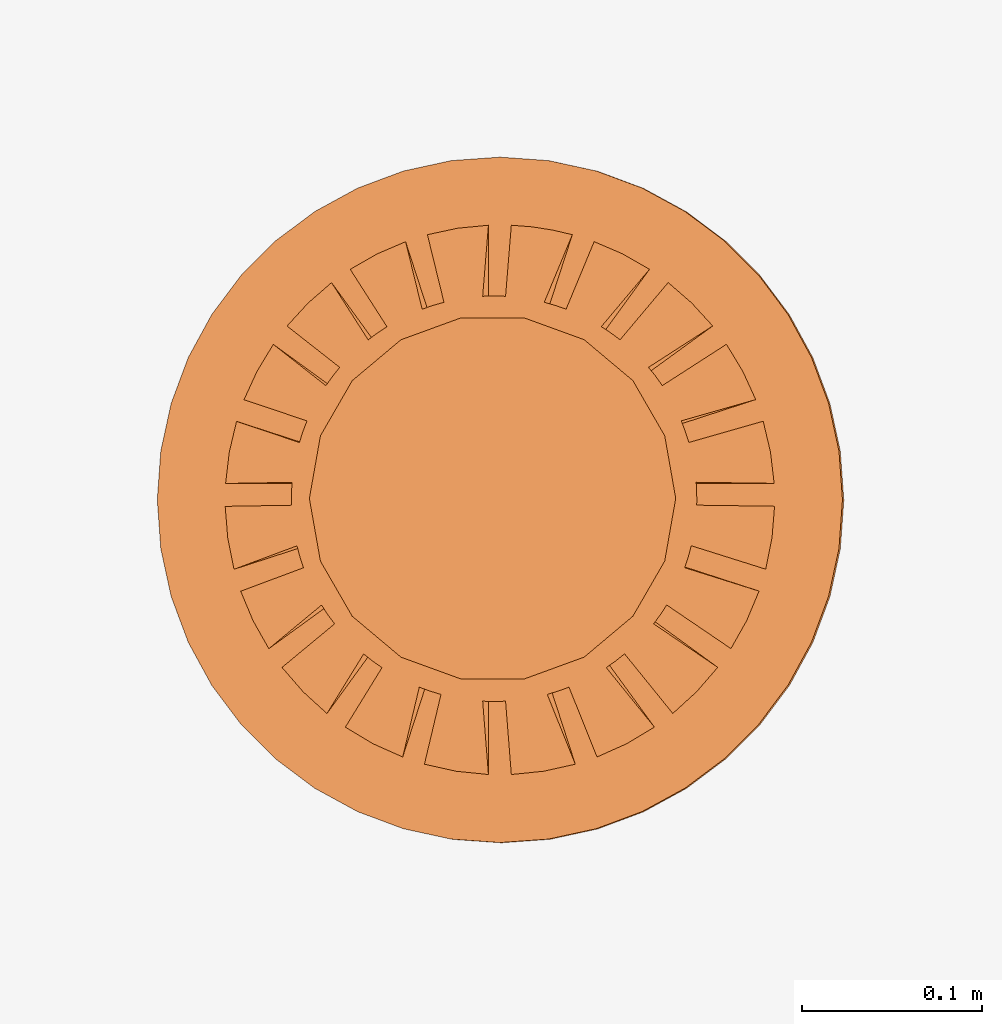
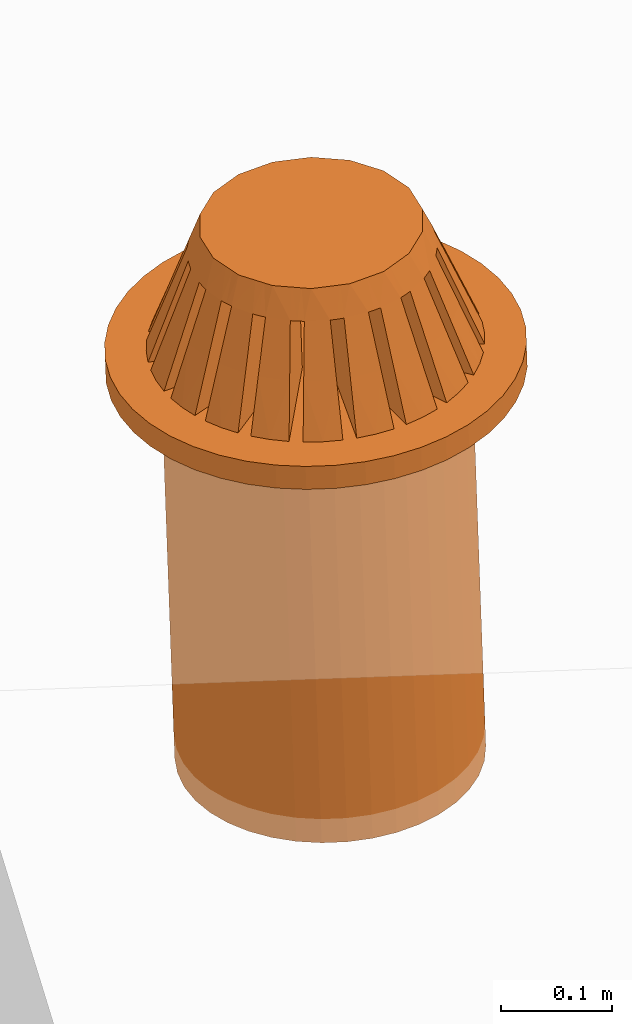
# One storey, part 13 of 18: 1 proxy.
"""IFC2X3 building model written with IfcOpenShell, lengths in centimetres."""

from ifc_helpers import new_model, entity, si_unit, converted_unit, derived_unit, direction, frame, frame_2d, origin, place, context, subcontext, project, spatial, circle, extrude, faceted_brep, source, transform, mapped, type_object, type_shapes, element, save


model = new_model("IFC2X3")

# Units and contexts
model_context = context("Model", 3, precision=0.001, world=origin(), true_north=direction((6.12303176911189e-17, 1.0)))
body_context = subcontext(model_context, "Body", "Model", "MODEL_VIEW")
ifc_project = project(units=[si_unit("LENGTHUNIT", "METRE", prefix="CENTI"), si_unit("AREAUNIT", "SQUARE_METRE"), si_unit("VOLUMEUNIT", "CUBIC_METRE"), converted_unit("PLANEANGLEUNIT", "DEGREE", entity("IfcRatioMeasure", 0.0174532925199433), si_unit("PLANEANGLEUNIT", "RADIAN"), dimensions=[0, 0, 0, 0, 0, 0, 0]), si_unit("MASSUNIT", "GRAM", prefix="KILO"), derived_unit("MASSDENSITYUNIT", [(si_unit("MASSUNIT", "GRAM", prefix="KILO"), 1), (si_unit("LENGTHUNIT", "METRE"), -3)]), si_unit("TIMEUNIT", "SECOND"), si_unit("FREQUENCYUNIT", "HERTZ"), si_unit("THERMODYNAMICTEMPERATUREUNIT", "DEGREE_CELSIUS"), derived_unit("THERMALTRANSMITTANCEUNIT", [(si_unit("MASSUNIT", "GRAM", prefix="KILO"), 1), (si_unit("THERMODYNAMICTEMPERATUREUNIT", "KELVIN"), -1), (si_unit("TIMEUNIT", "SECOND"), -3)]), derived_unit("VOLUMETRICFLOWRATEUNIT", [(si_unit("LENGTHUNIT", "METRE"), 3), (si_unit("TIMEUNIT", "SECOND"), -1)]), si_unit("ELECTRICCURRENTUNIT", "AMPERE"), si_unit("ELECTRICVOLTAGEUNIT", "VOLT"), si_unit("POWERUNIT", "WATT"), si_unit("FORCEUNIT", "NEWTON", prefix="KILO"), si_unit("ILLUMINANCEUNIT", "LUX"), si_unit("LUMINOUSFLUXUNIT", "LUMEN"), si_unit("LUMINOUSINTENSITYUNIT", "CANDELA"), derived_unit("USERDEFINED", [(si_unit("MASSUNIT", "GRAM", prefix="KILO"), -1), (si_unit("LENGTHUNIT", "METRE"), -2), (si_unit("TIMEUNIT", "SECOND"), 3), (si_unit("LUMINOUSFLUXUNIT", "LUMEN"), 1)]), derived_unit("LINEARVELOCITYUNIT", [(si_unit("LENGTHUNIT", "METRE"), 1), (si_unit("TIMEUNIT", "SECOND"), -1)]), si_unit("PRESSUREUNIT", "PASCAL"), derived_unit("USERDEFINED", [(si_unit("LENGTHUNIT", "METRE"), -2), (si_unit("MASSUNIT", "GRAM", prefix="KILO"), 1), (si_unit("TIMEUNIT", "SECOND"), -2)])], contexts=[model_context])

# Site, building, storey
site_placement = place(None, origin())
site = spatial("IfcSite", under=ifc_project, at=site_placement, CompositionType="ELEMENT")
building_placement = place(site_placement, origin())
building = spatial("IfcBuilding", under=site, at=building_placement, CompositionType="ELEMENT")
storey_placement = place(building_placement, frame((0.0, 0.0, 1422.0)))
storey = spatial("IfcBuildingStorey", under=building, at=storey_placement, CompositionType="ELEMENT", Elevation=1422.0)

# Proxy
building_element_proxy_type = type_object("IfcBuildingElementProxyType", PredefinedType="NOTDEFINED")
shared_shape = source(origin(), body_context, "Body", "SolidModel", [
    extrude(circle(Radius=19.0, at=frame_2d((0.0, -3.06953469142194e-14), x_axis=(1.0, 0.0))), origin(), (0.0, 0.0, 1.0), 2.54),
    extrude(circle(Radius=14.0, at=frame_2d((1.92355843129092e-27, -2.26176240420562e-14), x_axis=(1.0, 0.0))), frame((0.0, 0.0, -42.6697612033445)), (0.0, 0.0, 1.0), 42.6697612033443),
    faceted_brep([(0.635000000000694, -3.73200151378123, 2.53999999999981), (4.18391377444547, -14.6544350122444, 2.53999999999981), (2.43086019905985, -15.0448834722211, 2.53999999999981), (0.635000000000694, -15.2267650865205, 2.53999999999981), (-8.57165434960121, -12.6009659038898, 2.53999999999981), (-1.84284177569415, -3.33954993092504, 2.53999999999981), (-5.38954749961934, -14.2551877486548, 2.53999999999981), (-7.0271490791317, -13.5231939947521, 2.53999999999981), (2.87029335855171, -2.59306266051359, 2.53999999999981), (12.0835281839743, -9.28686958168313, 2.53999999999981), (10.9158204820288, -10.634964184435, 2.53999999999981), (9.59111679900109, -11.843482534627, 2.53999999999981), (-12.0835281839714, -9.28686958168203, 2.53999999999981), (-2.87029335855034, -2.5930626605136, 2.53999999999981), (-9.59111679899883, -11.8434825346258, 2.53999999999981), (-10.9091371340833, -10.6418197217289, 2.53999999999981), (3.61678062896316, -1.56561107765742, 2.53999999999981), (14.3750483455808, -5.06118415613312, 2.53999999999981), (13.6893933941843, -6.69761961441146, 2.53999999999981), (12.8148798460614, -8.24842133569207, 2.53999999999981), (-14.3750483455773, -5.06118415613243, 2.53999999999981), (-3.61678062896177, -1.56561107765742, 2.53999999999981), (-12.8148798460584, -8.2484213356909, 2.53999999999981), (-13.6854426476856, -6.70568859528176, 2.53999999999981), (4.00923221181935, -0.357769301962574, 2.53999999999981), (15.2357999831526, -0.357769301962576, 2.53999999999981), (15.091993692444, -2.11880305533537, 2.53999999999981), (14.7465821637106, -3.8465457866775, 2.53999999999981), (-4.18391377444389, -14.6544350122438, 2.53999999999981), (-0.634999999999306, -3.73200151378123, 2.53999999999981), (-0.634999999999306, -15.2267650865204, 2.53999999999981), (-2.43017839604844, -15.0449936179264, 2.53999999999981), (1.84284177569554, -3.33954993092504, 2.53999999999981), (8.57165434960338, -12.6009659038909, 2.53999999999981), (7.02577035383633, -13.5239103418815, 2.53999999999981), (5.38954749962098, -14.2551877486556, 2.53999999999981), (-15.2357999831488, -0.357769301962569, 2.53999999999981), (-4.00923221181796, -0.357769301962574, 2.53999999999981), (-14.7465821637071, -3.84654578667679, 2.53999999999981), (-15.0914467339494, -2.12269533290175, 2.53999999999981), (14.6045478126464, 4.35485742454993, 2.53999999999981), (15.0066588257202, 2.65665031354838, 2.53999999999981), (15.2126735044702, 0.912230698037424, 2.53999999999981), (4.00923221181935, 0.912230698037425, 2.53999999999981), (-6.80575831032103, 13.6359544521607, 2.53999999999981), (-5.22880343434807, 14.3149297813457, 2.53999999999981), (-1.84284177569414, 3.89401132699988, 2.53999999999981), (-8.30000315425477, 12.7815315060154, 2.53999999999981), (0.635000000000694, 15.2267650865154, 2.53999999999981), (1.77660370807615, 15.1360919415938, 2.53999999999981), (2.90596513611333, 14.9603798958325, 2.53999999999981), (4.01875360813548, 14.7005856834699, 2.53999999999981), (0.635000000000694, 4.28646290985607, 2.53999999999981), (-15.0074040021538, 2.65243758005144, 2.53999999999981), (-14.6045478126429, 4.35485742454923, 2.53999999999981), (-4.00923221181797, 0.912230698037428, 2.53999999999981), (-15.2126735044665, 0.91223069803743, 2.53999999999981), (12.5663533924978, 8.62231769391866, 2.53999999999981), (13.4643458163018, 7.13925708593345, 2.53999999999981), (14.1911784650638, 5.55590260648399, 2.53999999999981), (3.61678062896317, 2.12007247373227, 2.53999999999981), (-13.467959911725, 7.1324368778196, 2.53999999999981), (-12.5663533924948, 8.62231769391751, 2.53999999999981), (-3.61678062896178, 2.12007247373227, 2.53999999999981), (-14.1911784650603, 5.5559026064833, 2.53999999999981), (9.33544387057166, 12.0460403344576, 2.53999999999981), (10.6372524386057, 10.9135906354124, 2.53999999999981), (11.8047305137619, 9.63877261363989, 2.53999999999981), (2.87029335855172, 3.14752405658845, 2.53999999999981), (-10.6420383482958, 10.9089238604597, 2.53999999999981), (-9.33544387056942, 12.0460403344565, 2.53999999999981), (-2.87029335855033, 3.14752405658845, 2.53999999999981), (-11.804730513759, 9.63877261363881, 2.53999999999981), (5.22880343434972, 14.3149297813465, 2.53999999999981), (6.80772607331836, 13.6349721565766, 2.53999999999981), (8.30000315425692, 12.7815315060165, 2.53999999999981), (1.84284177569554, 3.8940113269999, 2.53999999999981), (-2.34556631288643, 15.0584168713636, 2.53999999999981), (-0.634999999999306, 15.2267650865153, 2.53999999999981), (-0.634999999999306, 4.28646290985609, 2.53999999999981), (-4.01875360813389, 14.7005856834693, 2.53999999999981), (-10.1842131428712, 8.46139782631736, 7.78842875148637), (-2.87029335855033, 3.14752405658845, 13.0363510851103), (-8.56279262952923, 7.28336686759414, 13.0363510851103), (11.1943624751735, -7.07104654837063, 7.78842875148637), (9.57294196183155, -5.8930155896474, 13.0363510851103), (3.61678062896316, -1.56561107765742, 13.0363510851103), (12.4729292779123, -4.44314820646743, 7.78822254411232), (10.5706129058111, -3.82504814870544, 13.0363510851103), (-12.7024287449743, 3.73682147488353, 7.78822254411232), (-10.8001123728732, 3.11872141712155, 13.0363510851103), (-4.00923221181796, 0.912230698037428, 13.0363510851103), (-12.2858092879303, 4.9368106322387, 7.78845268437236), (-3.61678062896178, 2.12007247373227, 13.0363510851103), (-10.3792782066206, 4.31734113244095, 13.0363510851103), (12.8412129865807, -3.22745381243289, 7.78845268437236), (10.934681905271, -2.60798431263514, 13.0363510851103), (4.00923221181934, -0.357769301962574, 13.0363510851103), (13.2358439831053, -0.357769301962576, 7.78821916765944), (11.2356954244486, -0.357769301962575, 13.0363510851103), (-13.2358439831016, -0.35776930196257, 7.78821916765943), (-11.2356954244448, -0.35776930196257, 13.0363510851103), (-4.00923221181795, -0.357769301962571, 13.0363510851103), (-13.209124060714, 0.91223069803743, 7.78846118750995), (-11.2043154943918, 0.912230698037429, 13.0363510851103), (13.2091240607178, 0.912230698037424, 7.78846118750995), (11.2043154943956, 0.912230698037424, 13.0363510851103), (4.00923221181935, 0.912230698037428, 13.0363510851103), (12.7024287449779, 3.73682147488424, 7.78822254411231), (10.8001123728767, 3.11872141712226, 13.0363510851103), (-12.4729292779088, -4.44314820646674, 7.78822254411232), (-10.5706129058076, -3.82504814870476, 13.0363510851103), (-3.61678062896177, -1.56561107765742, 13.0363510851103), (-12.8412129865771, -3.22745381243218, 7.78845268437236), (-10.9346819052674, -2.60798431263443, 13.0363510851103), (12.2858092879338, 4.93681063223938, 7.78845268437236), (10.3792782066241, 4.31734113244163, 13.0363510851103), (3.61678062896317, 2.12007247373227, 13.0363510851103), (10.9481874613231, 7.44665132755081, 7.78823305884087), (9.32981615814522, 6.27083574968865, 13.0363510851103), (-10.4653622527966, -8.11120321531418, 7.78823305884087), (-8.84699094961877, -6.93538763745202, 13.0363510851103), (-2.87029335855034, -2.59306266051361, 13.0363510851103), (-11.1943624751705, -7.07104654836945, 7.78842875148637), (-9.57294196182853, -5.89301558964622, 13.0363510851103), (10.1842131428741, 8.46139782631843, 7.78842875148638), (8.56279262953209, 7.2833668675952, 13.0363510851103), (2.87029335855172, 3.14752405658845, 13.0363510851103), (-0.634999999999306, -13.2254069753517, 7.78831335316191), (-0.634999999999306, -3.73200151378123, 13.0363510851103), (-0.634999999999306, -11.223440895929, 13.0363510851103), (-0.634999999999306, 13.2254069753467, 7.78831335316191), (-0.634999999999306, 11.223440895924, 13.0363510851103), (-0.634999999999306, 4.28646290985609, 13.0363510851103), (0.635000000000694, 13.2254069753468, 7.78831335316191), (0.635000000000694, 4.28646290985607, 13.0363510851103), (0.635000000000694, 11.2234408959241, 13.0363510851103), (0.635000000000693, -13.2254069753518, 7.78831335316191), (0.635000000000693, -11.2234408959292, 13.0363510851103), (0.635000000000695, -3.73200151378123, 13.0363510851103), (7.395825950438, -10.9825769537031, 7.78825156071356), (1.84284177569554, -3.33954993092504, 13.0363510851103), (6.21980036170794, -9.36391659536358, 13.0363510851103), (-8.15961547140403, 10.4276513842687, 7.78825156071356), (-6.98358988267396, 8.80899102592914, 13.0363510851103), (-7.12293375046627, 11.1614344595012, 7.78839367121062), (-1.84284177569415, 3.89401132699989, 13.0363510851103), (-5.94529897297529, 9.5405592428445, 13.0363510851103), (8.4140473952126, -10.2233854881127, 7.78839367121062), (7.23641261772162, -8.60251027145605, 13.0363510851103), (2.87029335855172, -2.5930626605136, 13.0363510851103), (10.4653622527995, -8.11120321531528, 7.78823305884087), (8.84699094962167, -6.93538763745311, 13.0363510851103), (-10.9481874613201, 7.44665132754965, 7.78823305884087), (-9.32981615814222, 6.27083574968748, 13.0363510851103), (8.15961547140628, 10.4276513842699, 7.78825156071356), (6.98358988267623, 8.80899102593034, 13.0363510851103), (-7.39582595043583, -10.982576953702, 7.78825156071356), (-6.21980036170578, -9.36391659536252, 13.0363510851103), (-1.84284177569415, -3.33954993092504, 13.0363510851103), (-8.41404739521033, -10.2233854881115, 7.78839367121062), (-7.23641261771934, -8.60251027145481, 13.0363510851103), (7.12293375046841, 11.1614344595022, 7.78839367121062), (5.94529897297742, 9.54055924284552, 13.0363510851103), (1.84284177569554, 3.8940113269999, 13.0363510851103), (4.61050960133581, 12.4120170303426, 7.78827857144105), (3.99207528530712, 10.5086719170768, 13.0363510851103), (-3.56561994142997, -12.7515222612399, 7.78827857144105), (-2.94718562540128, -10.8481771479742, 13.0363510851103), (-4.7709107140866, -12.3512194983297, 7.78835325421778), (-4.15203171408524, -10.446505788522, 13.0363510851103), (3.40011682260275, 12.7966174331448, 7.78835325421778), (2.78123782260139, 10.8919037233371, 13.0363510851103), (3.56561994143155, -12.7515222612405, 7.78827857144105), (2.94718562540286, -10.8481771479748, 13.0363510851103), (-4.61050960133415, 12.4120170303418, 7.78827857144105), (-3.99207528530546, 10.508671917076, 13.0363510851103), (-3.40011682260117, 12.7966174331442, 7.78835325421778), (-2.78123782259981, 10.8919037233365, 13.0363510851103), (4.77091071408826, -12.3512194983305, 7.78835325421777), (4.15203171408689, -10.4465057885229, 13.0363510851103), (-2.59319911382011, 9.70393960356297, 15.8749999999998), (-3.4221327425461, 9.40223243652444, 15.8749999999998), (-5.07999999999809, 8.79881810244738, 15.8749999999998), (-5.7557528855203, 8.23179410543872, 15.8749999999998), (-6.4315057710425, 7.66477010843005, 15.8749999999998), (-7.78301154208691, 6.53072211441273, 15.8749999999998), (-8.22407791336091, 5.76677274985612, 15.8749999999998), (-8.66514428463491, 5.00282338529952, 15.8749999999998), (-9.10621065590892, 4.23887402074291, 15.8749999999998), (-9.54727702718292, 3.4749246561863, 15.8749999999998), (-9.70045777038672, 2.60619349213911, 15.8749999999998), (-9.85363851359051, 1.73746232809191, 15.8749999999998), (-10.0068192567943, 0.868731164044709, 15.8749999999998), (-10.1599999999981, 0.0, 15.8749999999998), (-9.85363851359053, -1.73746232809688, 15.8749999999998), (-9.70045777038674, -2.60619349214408, 15.8749999999998), (-9.54727702718295, -3.47492465619127, 15.8749999999998), (-8.66514428463495, -5.0028233853045, 15.8749999999998), (-8.22407791336095, -5.76677274986111, 15.8749999999998), (-7.78301154208695, -6.53072211441772, 15.8749999999998), (-6.43150577104255, -7.66477010843505, 15.8749999999998), (-5.75575288552035, -8.23179410544372, 15.8749999999998), (-5.07999999999815, -8.79881810245239, 15.8749999999998), (-3.42213274254616, -9.40223243652946, 15.8749999999998), (-2.59319911382017, -9.70393960356799, 15.8749999999998), (-1.76426548509418, -10.0056467706065, 15.8749999999998), (-0.88213274254617, -10.0056467706065, 15.8749999999998), (0.0, -10.0056467706065, 15.8749999999998), (0.882132742549835, -10.0056467706065, 15.8749999999998), (1.76426548509784, -10.0056467706065, 15.8749999999998), (2.59319911382384, -9.70393960356802, 15.8749999999998), (3.42213274254983, -9.40223243652949, 15.8749999999998), (5.08000000000183, -8.79881810245243, 15.8749999999998), (5.75575288552403, -8.23179410544377, 15.8749999999998), (6.43150577104623, -7.66477010843511, 15.8749999999998), (7.78301154209065, -6.53072211441779, 15.8749999999998), (8.22407791336465, -5.76677274986118, 15.8749999999998), (8.66514428463866, -5.00282338530458, 15.8749999999998), (9.54727702718667, -3.47492465619137, 15.8749999999998), (9.70045777039047, -2.60619349214417, 15.8749999999998), (9.85363851359427, -1.73746232809697, 15.8749999999998), (10.1600000000019, 0.0, 15.8749999999998), (10.0068192567981, 0.86873116404468, 15.8749999999998), (9.85363851359429, 1.73746232809188, 15.8749999999998), (9.70045777039049, 2.60619349213907, 15.8749999999998), (9.5472770271867, 3.47492465618627, 15.8749999999998), (9.1062106559127, 4.23887402074288, 15.8749999999998), (8.6651442846387, 5.00282338529949, 15.8749999999998), (8.2240779133647, 5.7667727498561, 15.8749999999998), (7.78301154209069, 6.53072211441271, 15.8749999999998), (6.43150577104629, 7.66477010843004, 15.8749999999998), (5.75575288552409, 8.2317941054387, 15.8749999999998), (5.08000000000188, 8.79881810244737, 15.8749999999998), (3.42213274254989, 9.40223243652443, 15.8749999999998), (2.5931991138239, 9.70393960356297, 15.8749999999998), (1.7642654850979, 10.0056467706015, 15.8749999999998), (0.8821327425499, 10.0056467706015, 15.8749999999998), (0.0, 10.0056467706015, 15.8749999999998), (-0.882132742546106, 10.0056467706015, 15.8749999999998), (-1.76426548509411, 10.0056467706015, 15.8749999999998), (10.7698531709191, -3.22166311417828, 13.0363510851103), (11.2399663130641, -0.178907310034193, 13.0363510851103), (11.2413900628169, 0.0, 13.0363510851103), (3.5552857379653, -10.6643702986086, 13.0363510851103), (9.22470145788588, -6.42446367857287, 13.0363510851103), (6.73886873551225, -8.99758293709833, 13.0363510851103), (-6.73886873550998, -8.99758293709723, 13.0363510851103), (0.0, -11.2413900628176, 13.0363510851103), (-3.55528573796362, -10.6643702986079, 13.0363510851103), (-10.7698531709156, -3.22166311417766, 13.0363510851103), (-11.2399663130604, -0.178907310034141, 13.0363510851103), (-11.2413900628132, 0.0, 13.0363510851103), (-9.22470145788288, -6.42446367857179, 13.0363510851103), (-8.96061756372554, 6.78794397597258, 13.0363510851103), (-10.6066403085603, 3.72398065369879, 13.0363510851103), (-11.2321175965086, 0.456491886581969, 13.0363510851103), (-3.39207300463341, 10.7174013303379, 13.0363510851103), (-6.47478492109452, 9.18945105922292, 13.0363510851103), (8.96061756372843, 6.78794397597374, 13.0363510851103), (3.39207300463496, 10.7174013303386, 13.0363510851103), (0.0, 11.2413900628125, 13.0363510851103), (10.6066403085638, 3.72398065369954, 13.0363510851103), (11.2321175965123, 0.45649188658195, 13.0363510851103), (6.47478492109666, 9.18945105922407, 13.0363510851103)], [[[0, 1, 2, 3]], [[4, 5, 6, 7]], [[8, 9, 10, 11]], [[12, 13, 14, 15]], [[16, 17, 18, 19]], [[20, 21, 22, 23]], [[24, 25, 26, 27]], [[28, 29, 30, 31]], [[32, 33, 34, 35]], [[36, 37, 38, 39]], [[40, 41, 42, 43]], [[44, 45, 46, 47]], [[48, 49, 50, 51, 52]], [[53, 54, 55, 56]], [[57, 58, 59, 60]], [[61, 62, 63, 64]], [[65, 66, 67, 68]], [[69, 70, 71, 72]], [[73, 74, 75, 76]], [[77, 78, 79, 80]], [[81, 72, 71, 82, 83]], [[84, 85, 86, 16, 19]], [[87, 17, 16, 86, 88]], [[89, 90, 91, 55, 54]], [[92, 64, 63, 93, 94]], [[95, 96, 97, 24, 27]], [[98, 25, 24, 97, 99]], [[100, 101, 102, 37, 36]], [[103, 56, 55, 91, 104]], [[105, 106, 107, 43, 42]], [[108, 40, 43, 107, 109]], [[110, 111, 112, 21, 20]], [[113, 38, 37, 102, 114]], [[115, 116, 117, 60, 59]], [[118, 57, 60, 117, 119]], [[120, 121, 122, 13, 12]], [[123, 22, 21, 112, 124]], [[125, 126, 127, 68, 67]], [[128, 30, 29, 129, 130]], [[131, 132, 133, 79, 78]], [[134, 48, 52, 135, 136]], [[137, 138, 139, 0, 3]], [[140, 33, 32, 141, 142]], [[143, 144, 82, 71, 70]], [[145, 47, 46, 146, 147]], [[148, 149, 150, 8, 11]], [[151, 9, 8, 150, 152]], [[153, 154, 93, 63, 62]], [[155, 65, 68, 127, 156]], [[157, 158, 159, 5, 4]], [[160, 14, 13, 122, 161]], [[162, 163, 164, 76, 75]], [[165, 73, 76, 164, 166]], [[167, 168, 129, 29, 28]], [[169, 6, 5, 159, 170]], [[171, 172, 135, 52, 51]], [[173, 1, 0, 139, 174]], [[175, 176, 146, 46, 45]], [[177, 80, 79, 133, 178]], [[179, 180, 141, 32, 35]], [[181, 182, 183, 184, 185, 186, 187, 188, 189, 190, 191, 192, 193, 194, 195, 196, 197, 198, 199, 200, 201, 202, 203, 204, 205, 206, 207, 208, 209, 210, 211, 212, 213, 214, 215, 216, 217, 218, 219, 220, 221, 222, 223, 224, 225, 226, 227, 228, 229, 230, 231, 232, 233, 234, 235, 236, 237, 238, 239, 240]], [[220, 241, 96]], [[241, 220, 219]], [[219, 218, 88]], [[219, 88, 241]], [[216, 152, 217]], [[87, 88, 85]], [[222, 99, 242]], [[242, 243, 222]], [[84, 87, 85]], [[99, 96, 98]], [[99, 222, 221]], [[96, 95, 98]], [[213, 142, 214]], [[211, 210, 174]], [[213, 212, 180]], [[174, 210, 138]], [[244, 212, 211]], [[209, 208, 138, 210]], [[130, 208, 207, 206]], [[216, 149, 152]], [[245, 217, 152]], [[246, 215, 214]], [[149, 215, 246]], [[213, 180, 142]], [[151, 152, 149]], [[142, 180, 140]], [[85, 218, 217]], [[173, 174, 138]], [[98, 95, 26]], [[9, 151, 10]], [[84, 18, 87]], [[10, 151, 148]], [[27, 26, 95]], [[26, 25, 98]], [[87, 18, 17]], [[19, 18, 84]], [[180, 179, 140]], [[34, 140, 179]], [[2, 173, 137]], [[137, 173, 138]], [[2, 137, 3]], [[140, 34, 33]], [[35, 34, 179]], [[173, 2, 1]], [[148, 11, 10]], [[148, 151, 149]], [[204, 203, 170]], [[158, 202, 247]], [[161, 201, 200]], [[161, 200, 121]], [[180, 212, 244]], [[201, 247, 202]], [[206, 168, 130]], [[248, 208, 130]], [[167, 130, 168]], [[170, 249, 204]], [[205, 204, 249]], [[157, 170, 158]], [[203, 158, 170]], [[250, 196, 114]], [[138, 208, 248]], [[99, 221, 96]], [[200, 199, 121]], [[198, 124, 199]], [[88, 218, 85]], [[111, 197, 250]], [[195, 194, 101]], [[111, 124, 198]], [[111, 198, 197]], [[110, 124, 111]], [[197, 196, 250]], [[100, 113, 114]], [[244, 211, 174]], [[114, 195, 101]], [[194, 251, 101]], [[100, 114, 101]], [[194, 252, 251]], [[161, 121, 120]], [[158, 203, 202]], [[130, 167, 128]], [[31, 128, 167]], [[96, 221, 220]], [[157, 169, 170]], [[14, 160, 15]], [[169, 157, 7]], [[247, 201, 161]], [[85, 217, 245]], [[128, 31, 30]], [[167, 28, 31]], [[121, 199, 253]], [[6, 169, 7]], [[157, 4, 7]], [[246, 214, 142]], [[15, 120, 12]], [[120, 15, 160]], [[114, 196, 195]], [[124, 110, 123]], [[113, 100, 39]], [[23, 123, 110]], [[205, 249, 168]], [[160, 161, 120]], [[113, 39, 38]], [[22, 123, 23]], [[23, 110, 20]], [[168, 206, 205]], [[100, 36, 39]], [[199, 124, 253]], [[149, 216, 215]], [[191, 190, 90, 192]], [[188, 94, 190, 189]], [[154, 187, 254]], [[153, 94, 154]], [[187, 186, 254]], [[255, 190, 94]], [[252, 194, 256]], [[90, 104, 192]], [[256, 194, 193]], [[89, 104, 90]], [[103, 104, 89]], [[90, 190, 255]], [[183, 147, 184]], [[181, 240, 178]], [[182, 181, 257]], [[238, 132, 240, 239]], [[237, 236, 136, 238]], [[131, 178, 132]], [[240, 132, 178]], [[144, 185, 184]], [[83, 186, 185]], [[143, 83, 144]], [[183, 176, 147]], [[258, 184, 147]], [[175, 147, 176]], [[257, 176, 182]], [[186, 83, 254]], [[92, 94, 153]], [[153, 61, 92]], [[72, 81, 69]], [[69, 81, 143]], [[89, 54, 53]], [[56, 103, 53]], [[92, 61, 64]], [[153, 62, 61]], [[53, 103, 89]], [[143, 81, 83]], [[145, 147, 175]], [[175, 44, 145]], [[77, 177, 131]], [[131, 177, 178]], [[77, 131, 78]], [[145, 44, 47]], [[45, 44, 175]], [[177, 77, 80]], [[143, 70, 69]], [[166, 234, 233]], [[231, 126, 156]], [[126, 231, 230]], [[126, 230, 259]], [[176, 183, 182]], [[231, 156, 232]], [[260, 235, 234]], [[172, 136, 236]], [[172, 236, 235]], [[134, 136, 172]], [[233, 163, 166]], [[235, 260, 172]], [[132, 238, 261]], [[165, 166, 163]], [[232, 163, 233]], [[126, 155, 156]], [[136, 261, 238]], [[228, 116, 119]], [[259, 230, 229]], [[118, 119, 116]], [[104, 193, 192]], [[262, 226, 109]], [[223, 222, 263]], [[226, 262, 116]], [[226, 116, 228, 227]], [[259, 229, 119]], [[109, 226, 225, 224]], [[144, 184, 258]], [[106, 108, 109]], [[223, 263, 106]], [[222, 243, 263]], [[105, 108, 106]], [[94, 188, 154]], [[118, 116, 115]], [[171, 49, 134]], [[171, 134, 172]], [[106, 224, 223]], [[257, 181, 178]], [[165, 162, 74]], [[163, 162, 165]], [[162, 75, 74]], [[171, 50, 49]], [[49, 48, 134]], [[51, 50, 171]], [[165, 74, 73]], [[155, 125, 66]], [[232, 156, 264]], [[66, 125, 67]], [[155, 66, 65]], [[109, 224, 106]], [[260, 234, 166]], [[83, 185, 144]], [[118, 115, 58]], [[163, 232, 264]], [[256, 193, 104]], [[58, 57, 118]], [[115, 59, 58]], [[108, 41, 40]], [[108, 105, 41]], [[154, 188, 187]], [[105, 42, 41]], [[119, 229, 228]], [[126, 125, 155]], [[117, 116, 262, 109, 107, 106, 263, 243, 242, 99, 97, 96, 241, 88, 86, 85, 245, 152, 150, 149, 246, 142, 141, 180, 244, 174, 139, 138, 248, 130, 129, 168, 249, 170, 159, 158, 247, 161, 122, 121, 253, 124, 112, 111, 250, 114, 102, 101, 251, 252, 256, 104, 91, 90, 255, 94, 93, 154, 254, 83, 82, 144, 258, 147, 146, 176, 257, 178, 133, 132, 261, 136, 135, 172, 260, 166, 164, 163, 264, 156, 127, 126, 259, 119]]]),
])
type_shapes(building_element_proxy_type, [shared_shape])
proxy_placement = place(storey_placement, frame((3831.07106723279, 1530.92965171807, -176.599795462953), z_axis=(-0.0304094864399185, 0.00594478764230235, 0.999519846043263), x_axis=(0.999537524625494, 0.000180861588497588, 0.0304089485945403)))
element("IfcBuildingElementProxy", 1, at=proxy_placement, inside=storey, type_object=building_element_proxy_type, context=body_context, shape_type="MappedRepresentation", body=[
    mapped(shared_shape, transform((0.0, 0.0, 0.0), scale=1.0)),
])

save(model, "model.ifc")
